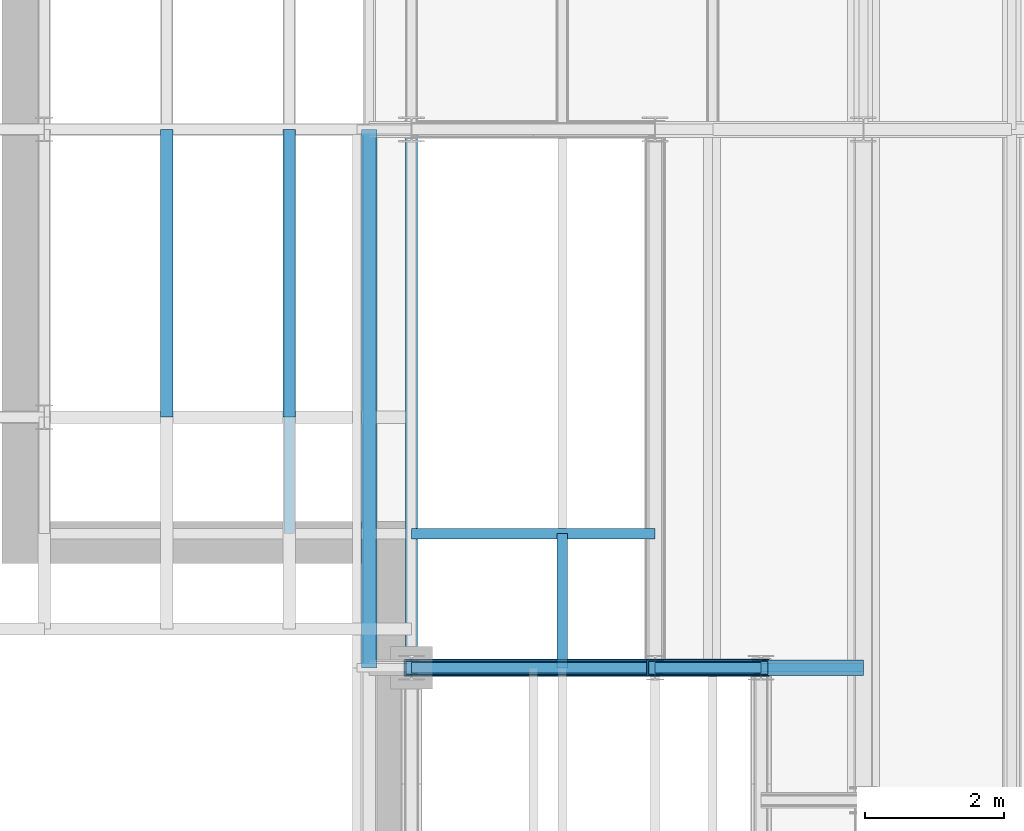
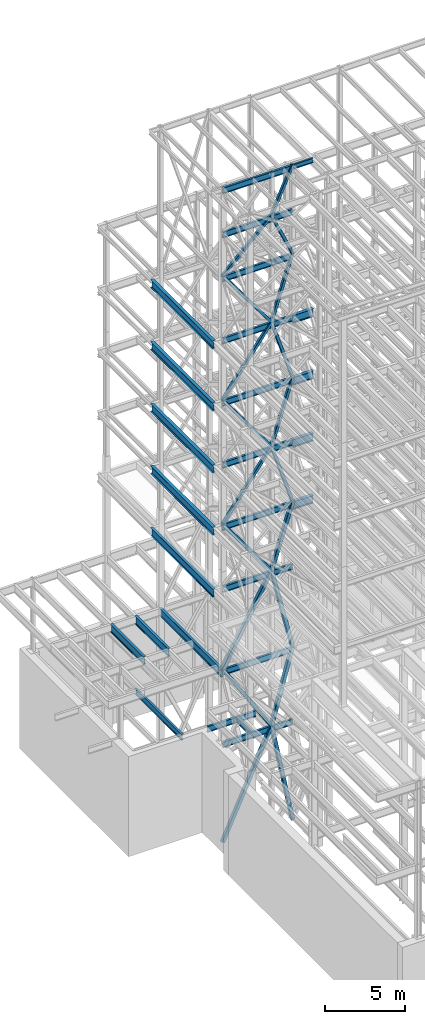
# One storey, part 126 of 150: 55 beams.
"""IFC2X3 building model written with IfcOpenShell, lengths in millimetres."""

from ifc_helpers import new_model, si_unit, frame, origin_with_axes, origin_2d_with_axis, place, context, subcontext, project, spatial, hollow_rectangle, i_section, extrude, material, type_object, element, save


model = new_model("IFC2X3")

# Units and contexts
model_context = context("Model", 3, precision=1e-05, world=origin_with_axes())
body_context = subcontext(model_context, "Body", "Model", "MODEL_VIEW")
ifc_project = project(units=[si_unit("LENGTHUNIT", "METRE", prefix="MILLI"), si_unit("AREAUNIT", "SQUARE_METRE"), si_unit("VOLUMEUNIT", "CUBIC_METRE"), si_unit("MASSUNIT", "GRAM", prefix="KILO"), si_unit("TIMEUNIT", "SECOND"), si_unit("PLANEANGLEUNIT", "RADIAN"), si_unit("SOLIDANGLEUNIT", "STERADIAN"), si_unit("THERMODYNAMICTEMPERATUREUNIT", "DEGREE_CELSIUS"), si_unit("LUMINOUSINTENSITYUNIT", "LUMEN")], contexts=[model_context])

# Site, building, storey
site_placement = place(None, origin_with_axes())
site = spatial("IfcSite", under=ifc_project, at=site_placement, CompositionType="ELEMENT")
building_placement = place(site_placement, origin_with_axes())
building = spatial("IfcBuilding", under=site, at=building_placement, Name="Undefined", CompositionType="ELEMENT")
storey_placement = place(building_placement, origin_with_axes())
storey = spatial("IfcBuildingStorey", under=building, at=storey_placement, Name="Undefined", CompositionType="ELEMENT", Elevation=0.0)

# Beams
ifc_material_1 = material()
beam_type_1 = type_object("IfcBeamType", Name="HSS8X8X3/8", PredefinedType="NOTDEFINED")
beam_1_placement = place(storey_placement, frame((5283.19999999999, 24384.0, 59207.4), z_axis=(-0.691222650508333, 0.0, 0.722641852804164), x_axis=(0.722641852804165, 0.0, 0.691222650508332)))
element("IfcBeam", 1, at=beam_1_placement, inside=storey, type_object=beam_type_1, material=ifc_material_1, Name="BEAM", ObjectType="HSS8X8X3/8", context=body_context, shape_type="SweptSolid", body=[
    extrude(hollow_rectangle(XDim=203.2, YDim=203.2, WallThickness=9.525, InnerFilletRadius=9.5249, OuterFilletRadius=19.0499, at=origin_2d_with_axis()), frame((4850.53495109736, -3.63797880709171e-12, -2.69258779222868e-13), z_axis=(-1.0, 0.0, 0.0), x_axis=(0.0, -1.0, 0.0)), (0.0, 0.0, 1.0), 4850.53495109736),
])
beam_2_placement = place(storey_placement, frame((8788.39962995178, 24383.9996510459, 62560.1997009414), z_axis=(-0.910366535681777, 0.0, 0.413802816218981), x_axis=(0.413802816218983, 0.0, 0.910366535681776)))
element("IfcBeam", 2, at=beam_2_placement, inside=storey, type_object=beam_type_1, material=ifc_material_1, Name="BEAM", ObjectType="HSS8X8X3/8", context=body_context, shape_type="SweptSolid", body=[
    extrude(hollow_rectangle(XDim=203.2, YDim=203.2, WallThickness=9.525, InnerFilletRadius=9.5249, OuterFilletRadius=19.0499, at=origin_2d_with_axis()), frame((3682.91263002186, 0.0, 0.0), z_axis=(-1.0, 0.0, 0.0), x_axis=(0.0, -1.0, 0.0)), (0.0, 0.0, 1.0), 3682.91263002186),
])
beam_3_placement = place(storey_placement, frame((10312.3994840967, 24383.9994993267, 59207.3999481708), z_axis=(0.910366480887262, 0.0, 0.413802936766938), x_axis=(-0.413802936766937, 0.0, 0.910366480887263)))
element("IfcBeam", 3, at=beam_3_placement, inside=storey, type_object=beam_type_1, material=ifc_material_1, Name="BEAM", ObjectType="HSS8X8X3/8", context=body_context, shape_type="SweptSolid", body=[
    extrude(hollow_rectangle(XDim=203.2, YDim=203.2, WallThickness=9.525, InnerFilletRadius=9.5249, OuterFilletRadius=19.0499, at=origin_2d_with_axis()), frame((3682.91245456265, 0.0, 0.0), z_axis=(-1.0, 0.0, 0.0), x_axis=(0.0, -1.0, 0.0)), (0.0, 0.0, 1.0), 3682.91245456265),
])
ifc_material_2 = material(Name="STEEL/A992")
beam_type_2 = type_object("IfcBeamType", Name="W18X35", PredefinedType="NOTDEFINED")
beam_4_placement = place(storey_placement, frame((5283.20000000002, 24384.0, 62334.7746954019), z_axis=(0.0, 0.0, 1.0), x_axis=(1.0, 0.0, 0.0)))
element("IfcBeam", 4, at=beam_4_placement, inside=storey, type_object=beam_type_2, material=ifc_material_2, Name="BEAM", ObjectType="W18X35", context=body_context, shape_type="SweptSolid", body=[
    extrude(i_section(OverallWidth=152.4, OverallDepth=450.85, WebThickness=7.9375, FlangeThickness=10.795, FilletRadius=17.78, at=origin_2d_with_axis()), frame((3505.19949708, 0.0, 0.0), z_axis=(-1.0, 0.0, 0.0), x_axis=(0.0, -1.0, 0.0)), (0.0, 0.0, 1.0), 3505.19949708),
])
beam_5_placement = place(storey_placement, frame((8788.39949708002, 24384.0, 62334.7746954019), z_axis=(0.0, 0.0, 1.0), x_axis=(1.0, 0.0, 0.0)))
element("IfcBeam", 5, at=beam_5_placement, inside=storey, type_object=beam_type_2, material=ifc_material_2, Name="BEAM", ObjectType="W18X35", context=body_context, shape_type="SweptSolid", body=[
    extrude(i_section(OverallWidth=152.4, OverallDepth=450.85, WebThickness=7.9375, FlangeThickness=10.795, FilletRadius=17.78, at=origin_2d_with_axis()), frame((1524.0, 0.0, 0.0), z_axis=(-1.0, 0.0, 0.0), x_axis=(0.0, -1.0, 0.0)), (0.0, 0.0, 1.0), 1524.0),
])
beam_6_placement = place(storey_placement, frame((5283.2, 24384.0, 65687.575), z_axis=(0.0, 0.0, 1.0), x_axis=(1.0, 0.0, 0.0)))
element("IfcBeam", 6, at=beam_6_placement, inside=storey, type_object=beam_type_2, material=ifc_material_2, Name="BEAM", ObjectType="W18X35", context=body_context, shape_type="SweptSolid", body=[
    extrude(i_section(OverallWidth=152.4, OverallDepth=450.85, WebThickness=7.9375, FlangeThickness=10.795, FilletRadius=17.78, at=origin_2d_with_axis()), frame((3505.19949708, 0.0, 0.0), z_axis=(-1.0, 0.0, 0.0), x_axis=(0.0, -1.0, 0.0)), (0.0, 0.0, 1.0), 3505.19949708),
])
beam_7_placement = place(storey_placement, frame((8788.39949708, 24384.0, 65687.575), z_axis=(0.0, 0.0, 1.0), x_axis=(1.0, 0.0, 0.0)))
element("IfcBeam", 7, at=beam_7_placement, inside=storey, type_object=beam_type_2, material=ifc_material_2, Name="BEAM", ObjectType="W18X35", context=body_context, shape_type="SweptSolid", body=[
    extrude(i_section(OverallWidth=152.4, OverallDepth=450.85, WebThickness=7.9375, FlangeThickness=10.795, FilletRadius=17.78, at=origin_2d_with_axis()), frame((1524.0, 0.0, 0.0), z_axis=(-1.0, 0.0, 0.0), x_axis=(0.0, -1.0, 0.0)), (0.0, 0.0, 1.0), 1524.0),
])
beam_8_placement = place(storey_placement, frame((5283.2, 24384.0, 58981.975), z_axis=(0.0, 0.0, 1.0), x_axis=(1.0, 0.0, 0.0)))
element("IfcBeam", 8, at=beam_8_placement, inside=storey, type_object=beam_type_2, material=ifc_material_2, Name="BEAM", ObjectType="W18X35", context=body_context, shape_type="SweptSolid", body=[
    extrude(i_section(OverallWidth=152.4, OverallDepth=450.85, WebThickness=7.9375, FlangeThickness=10.795, FilletRadius=17.78, at=origin_2d_with_axis()), frame((3505.19949708, 0.0, 0.0), z_axis=(-1.0, 0.0, 0.0), x_axis=(0.0, -1.0, 0.0)), (0.0, 0.0, 1.0), 3505.19949708),
])
beam_9_placement = place(storey_placement, frame((8788.39949708, 24384.0, 58981.975), z_axis=(0.0, 0.0, 1.0), x_axis=(1.0, 0.0, 0.0)))
element("IfcBeam", 9, at=beam_9_placement, inside=storey, type_object=beam_type_2, material=ifc_material_2, Name="BEAM", ObjectType="W18X35", context=body_context, shape_type="SweptSolid", body=[
    extrude(i_section(OverallWidth=152.4, OverallDepth=450.85, WebThickness=7.9375, FlangeThickness=10.795, FilletRadius=17.78, at=origin_2d_with_axis()), frame((1524.0, 0.0, 0.0), z_axis=(-1.0, 0.0, 0.0), x_axis=(0.0, -1.0, 0.0)), (0.0, 0.0, 1.0), 1524.0),
])
beam_10_placement = place(storey_placement, frame((5283.2, 24384.0, 54257.575), z_axis=(0.0, 0.0, 1.0), x_axis=(1.0, 0.0, 0.0)))
element("IfcBeam", 10, at=beam_10_placement, inside=storey, type_object=beam_type_2, material=ifc_material_2, Name="BEAM", ObjectType="W18X35", context=body_context, shape_type="SweptSolid", body=[
    extrude(i_section(OverallWidth=152.4, OverallDepth=450.85, WebThickness=7.9375, FlangeThickness=10.795, FilletRadius=17.78, at=origin_2d_with_axis()), frame((3505.19949708, 0.0, 0.0), z_axis=(-1.0, 0.0, 0.0), x_axis=(0.0, -1.0, 0.0)), (0.0, 0.0, 1.0), 3505.19949708),
])
beam_11_placement = place(storey_placement, frame((8788.39949708, 24384.0, 54257.575), z_axis=(0.0, 0.0, 1.0), x_axis=(1.0, 0.0, 0.0)))
element("IfcBeam", 11, at=beam_11_placement, inside=storey, type_object=beam_type_2, material=ifc_material_2, Name="BEAM", ObjectType="W18X35", context=body_context, shape_type="SweptSolid", body=[
    extrude(i_section(OverallWidth=152.4, OverallDepth=450.85, WebThickness=7.9375, FlangeThickness=10.795, FilletRadius=17.78, at=origin_2d_with_axis()), frame((1524.0, 0.0, 0.0), z_axis=(-1.0, 0.0, 0.0), x_axis=(0.0, -1.0, 0.0)), (0.0, 0.0, 1.0), 1524.0),
])
beam_12_placement = place(storey_placement, frame((5283.2, 24384.0, 49533.175), z_axis=(0.0, 0.0, 1.0), x_axis=(1.0, 0.0, 0.0)))
element("IfcBeam", 12, at=beam_12_placement, inside=storey, type_object=beam_type_2, material=ifc_material_2, Name="BEAM", ObjectType="W18X35", context=body_context, shape_type="SweptSolid", body=[
    extrude(i_section(OverallWidth=152.4, OverallDepth=450.85, WebThickness=7.9375, FlangeThickness=10.795, FilletRadius=17.78, at=origin_2d_with_axis()), frame((3505.19949708, 0.0, 0.0), z_axis=(-1.0, 0.0, 0.0), x_axis=(0.0, -1.0, 0.0)), (0.0, 0.0, 1.0), 3505.19949708),
])
beam_13_placement = place(storey_placement, frame((8788.39949708, 24384.0, 49533.175), z_axis=(0.0, 0.0, 1.0), x_axis=(1.0, 0.0, 0.0)))
element("IfcBeam", 13, at=beam_13_placement, inside=storey, type_object=beam_type_2, material=ifc_material_2, Name="BEAM", ObjectType="W18X35", context=body_context, shape_type="SweptSolid", body=[
    extrude(i_section(OverallWidth=152.4, OverallDepth=450.85, WebThickness=7.9375, FlangeThickness=10.795, FilletRadius=17.78, at=origin_2d_with_axis()), frame((1524.0, 0.0, 0.0), z_axis=(-1.0, 0.0, 0.0), x_axis=(0.0, -1.0, 0.0)), (0.0, 0.0, 1.0), 1524.0),
])
beam_14_placement = place(storey_placement, frame((5283.2, 24384.0, 44808.775), z_axis=(0.0, 0.0, 1.0), x_axis=(1.0, 0.0, 0.0)))
element("IfcBeam", 14, at=beam_14_placement, inside=storey, type_object=beam_type_2, material=ifc_material_2, Name="BEAM", ObjectType="W18X35", context=body_context, shape_type="SweptSolid", body=[
    extrude(i_section(OverallWidth=152.4, OverallDepth=450.85, WebThickness=7.9375, FlangeThickness=10.795, FilletRadius=17.78, at=origin_2d_with_axis()), frame((3505.19949708, 0.0, 0.0), z_axis=(-1.0, 0.0, 0.0), x_axis=(0.0, -1.0, 0.0)), (0.0, 0.0, 1.0), 3505.19949708),
])
beam_15_placement = place(storey_placement, frame((8788.39949708, 24384.0, 44808.775), z_axis=(0.0, 0.0, 1.0), x_axis=(1.0, 0.0, 0.0)))
element("IfcBeam", 15, at=beam_15_placement, inside=storey, type_object=beam_type_2, material=ifc_material_2, Name="BEAM", ObjectType="W18X35", context=body_context, shape_type="SweptSolid", body=[
    extrude(i_section(OverallWidth=152.4, OverallDepth=450.85, WebThickness=7.9375, FlangeThickness=10.795, FilletRadius=17.78, at=origin_2d_with_axis()), frame((1524.0, 0.0, 0.0), z_axis=(-1.0, 0.0, 0.0), x_axis=(0.0, -1.0, 0.0)), (0.0, 0.0, 1.0), 1524.0),
])
beam_16_placement = place(storey_placement, frame((5283.2, 24384.0, 40084.375), z_axis=(0.0, 0.0, 1.0), x_axis=(1.0, 0.0, 0.0)))
element("IfcBeam", 16, at=beam_16_placement, inside=storey, type_object=beam_type_2, material=ifc_material_2, Name="BEAM", ObjectType="W18X35", context=body_context, shape_type="SweptSolid", body=[
    extrude(i_section(OverallWidth=152.4, OverallDepth=450.85, WebThickness=7.9375, FlangeThickness=10.795, FilletRadius=17.78, at=origin_2d_with_axis()), frame((3505.19949708, 0.0, 0.0), z_axis=(-1.0, 0.0, 0.0), x_axis=(0.0, -1.0, 0.0)), (0.0, 0.0, 1.0), 3505.19949708),
])
for number, where, z_axis, x_axis, name in (
    (17, (8788.39949708, 24384.0, 40084.375), (0.0, 0.0, 1.0), (1.0, 0.0, 0.0), "BEAM"),
    (18, (8788.39949708, 24384.0, 35359.975), (0.0, 0.0, 1.0), (1.0, 0.0, 0.0), "BEAM"),
):
    element("IfcBeam", number, at=place(storey_placement, frame(where, z_axis=z_axis, x_axis=x_axis)), inside=storey, type_object=beam_type_2, material=ifc_material_2, Name=name, ObjectType="W18X35", context=body_context, shape_type="SweptSolid", body=[
        extrude(i_section(OverallWidth=152.4, OverallDepth=450.85, WebThickness=7.9375, FlangeThickness=10.795, FilletRadius=17.78, at=origin_2d_with_axis()), frame((1524.0, 0.0, 0.0), z_axis=(-1.0, 0.0, 0.0), x_axis=(0.0, -1.0, 0.0)), (0.0, 0.0, 1.0), 1524.0),
    ])
beam_17_placement = place(storey_placement, frame((5283.2, 24384.0, 35359.975), z_axis=(0.0, 0.0, 1.0), x_axis=(1.0, 0.0, 0.0)))
element("IfcBeam", 19, at=beam_17_placement, inside=storey, type_object=beam_type_2, material=ifc_material_2, Name="BEAM", ObjectType="W18X35", context=body_context, shape_type="SweptSolid", body=[
    extrude(i_section(OverallWidth=152.4, OverallDepth=450.85, WebThickness=7.9375, FlangeThickness=10.795, FilletRadius=17.78, at=origin_2d_with_axis()), frame((3505.19949708, 0.0, 0.0), z_axis=(-1.0, 0.0, 0.0), x_axis=(0.0, -1.0, 0.0)), (0.0, 0.0, 1.0), 3505.19949708),
])
beam_18_placement = place(storey_placement, frame((8788.39949708, 24384.0, 29060.775), z_axis=(0.0, 0.0, 1.0), x_axis=(1.0, 0.0, 0.0)))
element("IfcBeam", 20, at=beam_18_placement, inside=storey, type_object=beam_type_2, material=ifc_material_2, Name="BEAM", ObjectType="W18X35", context=body_context, shape_type="SweptSolid", body=[
    extrude(i_section(OverallWidth=152.4, OverallDepth=450.85, WebThickness=7.9375, FlangeThickness=10.795, FilletRadius=17.78, at=origin_2d_with_axis()), frame((1524.0, 0.0, 0.0), z_axis=(-1.0, 0.0, 0.0), x_axis=(0.0, -1.0, 0.0)), (0.0, 0.0, 1.0), 1524.0),
])
beam_19_placement = place(storey_placement, frame((5283.2, 24384.0, 29060.775), z_axis=(0.0, 0.0, 1.0), x_axis=(1.0, 0.0, 0.0)))
element("IfcBeam", 21, at=beam_19_placement, inside=storey, type_object=beam_type_2, material=ifc_material_2, Name="BEAM", ObjectType="W18X35", context=body_context, shape_type="SweptSolid", body=[
    extrude(i_section(OverallWidth=152.4, OverallDepth=450.85, WebThickness=7.9375, FlangeThickness=10.795, FilletRadius=17.78, at=origin_2d_with_axis()), frame((3505.19949708, 0.0, 0.0), z_axis=(-1.0, 0.0, 0.0), x_axis=(0.0, -1.0, 0.0)), (0.0, 0.0, 1.0), 3505.19949708),
])
beam_20_placement = place(storey_placement, frame((3522.13333333333, 26314.4, 23548.975), z_axis=(0.0, 0.0, 1.0), x_axis=(0.0, 1.0, 0.0)))
element("IfcBeam", 22, at=beam_20_placement, inside=storey, type_object=beam_type_2, material=ifc_material_2, Name="BEAM", ObjectType="W18X35", context=body_context, shape_type="SweptSolid", body=[
    extrude(i_section(OverallWidth=152.4, OverallDepth=450.85, WebThickness=7.9375, FlangeThickness=10.795, FilletRadius=17.78, at=origin_2d_with_axis()), frame((5816.59941834001, 0.0, 0.0), z_axis=(-1.0, 0.0, 0.0), x_axis=(0.0, -1.0, 0.0)), (0.0, 0.0, 1.0), 5816.59941834001),
])
beam_21_placement = place(storey_placement, frame((5283.2, 26314.4, 23548.975), z_axis=(0.0, 0.0, 1.0), x_axis=(1.0, 0.0, 0.0)))
element("IfcBeam", 23, at=beam_21_placement, inside=storey, type_object=beam_type_2, material=ifc_material_2, Name="BEAM", ObjectType="W18X35", context=body_context, shape_type="SweptSolid", body=[
    extrude(i_section(OverallWidth=152.4, OverallDepth=450.85, WebThickness=7.9375, FlangeThickness=10.795, FilletRadius=17.78, at=origin_2d_with_axis()), frame((3505.19949708, 0.0, 0.0), z_axis=(-1.0, 0.0, 0.0), x_axis=(0.0, -1.0, 0.0)), (0.0, 0.0, 1.0), 3505.19949708),
])
beam_22_placement = place(storey_placement, frame((7450.66666666666, 24384.0, 23548.975), z_axis=(0.0, 0.0, 1.0), x_axis=(0.0, 1.0, 0.0)))
element("IfcBeam", 24, at=beam_22_placement, inside=storey, type_object=beam_type_2, material=ifc_material_2, Name="BEAM", ObjectType="W18X35", context=body_context, shape_type="SweptSolid", body=[
    extrude(i_section(OverallWidth=152.4, OverallDepth=450.85, WebThickness=7.9375, FlangeThickness=10.795, FilletRadius=17.78, at=origin_2d_with_axis()), frame((1930.4, 0.0, 0.0), z_axis=(-1.0, 0.0, 0.0), x_axis=(0.0, -1.0, 0.0)), (0.0, 0.0, 1.0), 1930.4),
])
beam_23_placement = place(storey_placement, frame((8788.39949708, 24384.0, 23548.975), z_axis=(0.0, 0.0, 1.0), x_axis=(1.0, 0.0, 0.0)))
element("IfcBeam", 25, at=beam_23_placement, inside=storey, type_object=beam_type_2, material=ifc_material_2, Name="BEAM", ObjectType="W18X35", context=body_context, shape_type="SweptSolid", body=[
    extrude(i_section(OverallWidth=152.4, OverallDepth=450.85, WebThickness=7.9375, FlangeThickness=10.795, FilletRadius=17.78, at=origin_2d_with_axis()), frame((1524.0, 0.0, 0.0), z_axis=(-1.0, 0.0, 0.0), x_axis=(0.0, -1.0, 0.0)), (0.0, 0.0, 1.0), 1524.0),
])
beam_24_placement = place(storey_placement, frame((5283.2, 24384.0, 23548.975), z_axis=(0.0, 0.0, 1.0), x_axis=(1.0, 0.0, 0.0)))
element("IfcBeam", 26, at=beam_24_placement, inside=storey, type_object=beam_type_2, material=ifc_material_2, Name="BEAM", ObjectType="W18X35", context=body_context, shape_type="SweptSolid", body=[
    extrude(i_section(OverallWidth=152.4, OverallDepth=450.85, WebThickness=7.9375, FlangeThickness=10.795, FilletRadius=17.78, at=origin_2d_with_axis()), frame((3505.19949708, 0.0, 0.0), z_axis=(-1.0, 0.0, 0.0), x_axis=(0.0, -1.0, 0.0)), (0.0, 0.0, 1.0), 3505.19949708),
])
beam_type_3 = type_object("IfcBeamType", Name="HSS8X8X1/4", PredefinedType="NOTDEFINED")
beam_25_placement = place(storey_placement, frame((8788.39890413715, 24383.9996510459, 54482.9985485445), z_axis=(0.803098244341145, 0.0, 0.595846632898241), x_axis=(-0.595846632898242, 0.0, 0.803098244341144)))
element("IfcBeam", 27, at=beam_25_placement, inside=storey, type_object=beam_type_3, material=ifc_material_1, Name="BEAM", ObjectType="HSS8X8X1/4", context=body_context, shape_type="SweptSolid", body=[
    extrude(hollow_rectangle(XDim=203.2, YDim=203.2, WallThickness=6.35, InnerFilletRadius=6.3499, OuterFilletRadius=12.6999, at=origin_2d_with_axis()), frame((5882.71947589545, 0.0, 3.26556530477498e-13), z_axis=(-1.0, 0.0, 0.0), x_axis=(0.0, -1.0, 0.0)), (0.0, 0.0, 1.0), 5882.71947589545),
])
beam_26_placement = place(storey_placement, frame((5283.19999999999, 24384.0, 49758.6), z_axis=(-0.803098029777427, 0.0, 0.595846922092927), x_axis=(0.595846922092929, 0.0, 0.803098029777426)))
element("IfcBeam", 28, at=beam_26_placement, inside=storey, type_object=beam_type_3, material=ifc_material_1, Name="BEAM", ObjectType="HSS8X8X1/4", context=body_context, shape_type="SweptSolid", body=[
    extrude(hollow_rectangle(XDim=203.2, YDim=203.2, WallThickness=6.35, InnerFilletRadius=6.3499, OuterFilletRadius=12.6999, at=origin_2d_with_axis()), frame((5882.71736269412, -3.63797880709171e-12, -6.53112826342519e-13), z_axis=(-1.0, 0.0, 0.0), x_axis=(0.0, -1.0, 0.0)), (0.0, 0.0, 1.0), 5882.71736269412),
])
beam_27_placement = place(storey_placement, frame((8788.39907224921, 24383.9996510459, 45034.1981868516), z_axis=(0.803098244341145, 0.0, 0.595846632898241), x_axis=(-0.595846632898242, 0.0, 0.803098244341144)))
element("IfcBeam", 29, at=beam_27_placement, inside=storey, type_object=beam_type_3, material=ifc_material_1, Name="BEAM", ObjectType="HSS8X8X1/4", context=body_context, shape_type="SweptSolid", body=[
    extrude(hollow_rectangle(XDim=203.2, YDim=203.2, WallThickness=6.35, InnerFilletRadius=6.3499, OuterFilletRadius=12.6999, at=origin_2d_with_axis()), frame((5882.71986653939, -3.63797880709171e-12, 0.0), z_axis=(-1.0, 0.0, 0.0), x_axis=(0.0, -1.0, 0.0)), (0.0, 0.0, 1.0), 5882.71986653939),
])
beam_28_placement = place(storey_placement, frame((5283.19999999999, 24384.0, 40309.8), z_axis=(-0.803098029777427, 0.0, 0.595846922092927), x_axis=(0.595846922092929, 0.0, 0.803098029777426)))
element("IfcBeam", 30, at=beam_28_placement, inside=storey, type_object=beam_type_3, material=ifc_material_1, Name="BEAM", ObjectType="HSS8X8X1/4", context=body_context, shape_type="SweptSolid", body=[
    extrude(hollow_rectangle(XDim=203.2, YDim=203.2, WallThickness=6.35, InnerFilletRadius=6.3499, OuterFilletRadius=12.6999, at=origin_2d_with_axis()), frame((5882.7176448609, -3.63797880709171e-12, -6.53112857669324e-13), z_axis=(-1.0, 0.0, 0.0), x_axis=(0.0, -1.0, 0.0)), (0.0, 0.0, 1.0), 5882.7176448609),
])
beam_29_placement = place(storey_placement, frame((8788.39897512157, 24383.9996510459, 54482.9987674781), z_axis=(-0.951708610220493, 0.0, 0.307002803296936), x_axis=(0.307002803296934, 0.0, 0.951708610220494)))
element("IfcBeam", 31, at=beam_29_placement, inside=storey, type_object=beam_type_3, material=ifc_material_1, Name="BEAM", ObjectType="HSS8X8X1/4", context=body_context, shape_type="SweptSolid", body=[
    extrude(hollow_rectangle(XDim=203.2, YDim=203.2, WallThickness=6.35, InnerFilletRadius=6.3499, OuterFilletRadius=12.6999, at=origin_2d_with_axis()), frame((4964.12576359461, -3.63797880709171e-12, 0.0), z_axis=(-1.0, 0.0, 0.0), x_axis=(0.0, -1.0, 0.0)), (0.0, 0.0, 1.0), 4964.12576359461),
])
beam_30_placement = place(storey_placement, frame((10312.3994243435, 24383.9994993267, 49758.5998073386), z_axis=(0.951708571577691, 0.0, 0.307002923089589), x_axis=(-0.307002923089589, 0.0, 0.95170857157769)))
element("IfcBeam", 32, at=beam_30_placement, inside=storey, type_object=beam_type_3, material=ifc_material_1, Name="BEAM", ObjectType="HSS8X8X1/4", context=body_context, shape_type="SweptSolid", body=[
    extrude(hollow_rectangle(XDim=203.2, YDim=203.2, WallThickness=6.35, InnerFilletRadius=6.3499, OuterFilletRadius=12.6999, at=origin_2d_with_axis()), frame((4964.12395196718, -3.63797880709171e-12, 0.0), z_axis=(-1.0, 0.0, 0.0), x_axis=(0.0, -1.0, 0.0)), (0.0, 0.0, 1.0), 4964.12395196718),
])
beam_31_placement = place(storey_placement, frame((8788.39945557969, 24383.9996510459, 45034.1987623571), z_axis=(-0.951708610220493, 0.0, 0.307002803296936), x_axis=(0.307002803296934, 0.0, 0.951708610220494)))
element("IfcBeam", 33, at=beam_31_placement, inside=storey, type_object=beam_type_3, material=ifc_material_1, Name="BEAM", ObjectType="HSS8X8X1/4", context=body_context, shape_type="SweptSolid", body=[
    extrude(hollow_rectangle(XDim=203.2, YDim=203.2, WallThickness=6.35, InnerFilletRadius=6.3499, OuterFilletRadius=12.6999, at=origin_2d_with_axis()), frame((4964.12562096637, 3.63797880709171e-12, 1.18505902984935e-12), z_axis=(-1.0, 0.0, 0.0), x_axis=(0.0, -1.0, 0.0)), (0.0, 0.0, 1.0), 4964.12562096637),
])
beam_32_placement = place(storey_placement, frame((10312.3994104483, 24383.9994993267, 40309.7997957603), z_axis=(0.951708571577691, 0.0, 0.307002923089589), x_axis=(-0.307002923089589, 0.0, 0.95170857157769)))
element("IfcBeam", 34, at=beam_32_placement, inside=storey, type_object=beam_type_3, material=ifc_material_1, Name="BEAM", ObjectType="HSS8X8X1/4", context=body_context, shape_type="SweptSolid", body=[
    extrude(hollow_rectangle(XDim=203.2, YDim=203.2, WallThickness=6.35, InnerFilletRadius=6.3499, OuterFilletRadius=12.6999, at=origin_2d_with_axis()), frame((4964.12395196718, -3.63797880709171e-12, 0.0), z_axis=(-1.0, 0.0, 0.0), x_axis=(0.0, -1.0, 0.0)), (0.0, 0.0, 1.0), 4964.1239587205),
])
beam_type_4 = type_object("IfcBeamType", Name="HSS10X10X1/2", PredefinedType="NOTDEFINED")
beam_33_placement = place(storey_placement, frame((8788.39819527373, 24383.999651046, 35585.4), z_axis=(0.803098244341145, 0.0, 0.595846632898241), x_axis=(-0.595846632898242, 0.0, 0.803098244341144)))
element("IfcBeam", 35, at=beam_33_placement, inside=storey, type_object=beam_type_4, material=ifc_material_1, Name="BEAM", ObjectType="HSS10X10X1/2", context=body_context, shape_type="SweptSolid", body=[
    extrude(hollow_rectangle(XDim=254.0, YDim=254.0, WallThickness=12.7, InnerFilletRadius=12.6999, OuterFilletRadius=25.3999, at=origin_2d_with_axis()), frame((5882.7178878602, 3.63797880709171e-12, 6.53112884647667e-13), z_axis=(-1.0, 0.0, 0.0), x_axis=(0.0, -1.0, 0.0)), (0.0, 0.0, 1.0), 5882.7178878602),
])
beam_34_placement = place(storey_placement, frame((5283.20033251794, 24384.0, 29286.2), z_axis=(-0.873824779009973, 0.0, 0.486240943965204), x_axis=(0.486240943965203, 0.0, 0.873824779009973)))
element("IfcBeam", 36, at=beam_34_placement, inside=storey, type_object=beam_type_4, material=ifc_material_1, Name="BEAM", ObjectType="HSS10X10X1/2", context=body_context, shape_type="SweptSolid", body=[
    extrude(hollow_rectangle(XDim=254.0, YDim=254.0, WallThickness=12.7, InnerFilletRadius=12.6999, OuterFilletRadius=25.3999, at=origin_2d_with_axis()), frame((7208.76776551082, 7.27595761418343e-12, -4.00166997622288e-13), z_axis=(-1.0, 0.0, 0.0), x_axis=(0.0, -1.0, 0.0)), (0.0, 0.0, 1.0), 7208.76776551082),
])
beam_35_placement = place(storey_placement, frame((8788.39819527374, 24383.999651046, 23774.4), z_axis=(0.843821721320064, 0.0, 0.536623613558372), x_axis=(-0.536623613558373, 0.0, 0.843821721320063)))
element("IfcBeam", 37, at=beam_35_placement, inside=storey, type_object=beam_type_4, material=ifc_material_1, Name="BEAM", ObjectType="HSS10X10X1/2", context=body_context, shape_type="SweptSolid", body=[
    extrude(hollow_rectangle(XDim=254.0, YDim=254.0, WallThickness=12.7, InnerFilletRadius=12.6999, OuterFilletRadius=25.3999, at=origin_2d_with_axis()), frame((6531.94850692104, 3.63797880709171e-12, -7.25191962804965e-13), z_axis=(-1.0, 0.0, 0.0), x_axis=(0.0, -1.0, 0.0)), (0.0, 0.0, 1.0), 6531.94850692104),
])
beam_36_placement = place(storey_placement, frame((8788.39819527373, 24383.999651046, 35585.4), z_axis=(-0.951708610220493, 0.0, 0.307002803296936), x_axis=(0.307002803296934, 0.0, 0.951708610220494)))
element("IfcBeam", 38, at=beam_36_placement, inside=storey, type_object=beam_type_4, material=ifc_material_1, Name="BEAM", ObjectType="HSS10X10X1/2", context=body_context, shape_type="SweptSolid", body=[
    extrude(hollow_rectangle(XDim=254.0, YDim=254.0, WallThickness=12.7, InnerFilletRadius=12.6999, OuterFilletRadius=25.3999, at=origin_2d_with_axis()), frame((4964.12483000856, -3.63797880709171e-12, 0.0), z_axis=(-1.0, 0.0, 0.0), x_axis=(0.0, -1.0, 0.0)), (0.0, 0.0, 1.0), 4964.12483000856),
])
beam_37_placement = place(storey_placement, frame((10312.3990503354, 24383.9994993267, 29286.1997756512), z_axis=(0.971958750820007, 0.0, 0.235151412295167), x_axis=(-0.235151412295168, 0.0, 0.971958750820007)))
element("IfcBeam", 39, at=beam_37_placement, inside=storey, type_object=beam_type_4, material=ifc_material_1, Name="BEAM", ObjectType="HSS10X10X1/2", context=body_context, shape_type="SweptSolid", body=[
    extrude(hollow_rectangle(XDim=254.0, YDim=254.0, WallThickness=12.7, InnerFilletRadius=12.6999, OuterFilletRadius=25.3999, at=origin_2d_with_axis()), frame((6480.93373463002, -3.63797880709171e-12, -1.79882046331404e-13), z_axis=(-1.0, 0.0, 0.0), x_axis=(0.0, -1.0, 0.0)), (0.0, 0.0, 1.0), 6480.93373463002),
])
beam_38_placement = place(storey_placement, frame((8788.39819527374, 24383.999651046, 23774.4), z_axis=(-0.963835356515138, 0.0, 0.266498415626315), x_axis=(0.266498415626315, 0.0, 0.963835356515138)))
element("IfcBeam", 40, at=beam_38_placement, inside=storey, type_object=beam_type_4, material=ifc_material_1, Name="BEAM", ObjectType="HSS10X10X1/2", context=body_context, shape_type="SweptSolid", body=[
    extrude(hollow_rectangle(XDim=254.0, YDim=254.0, WallThickness=12.7, InnerFilletRadius=12.6999, OuterFilletRadius=25.3999, at=origin_2d_with_axis()), frame((5718.61165038399, 0.0, 0.0), z_axis=(-1.0, 0.0, 0.0), x_axis=(0.0, -1.0, 0.0)), (0.0, 0.0, 1.0), 5718.61165038399),
])
beam_39_placement = place(storey_placement, frame((10312.399829598, 24383.9994993266, 16154.4), z_axis=(0.980580641075519, 0.0, 0.196116308215111), x_axis=(-0.196116308215111, 0.0, 0.980580641075519)))
element("IfcBeam", 41, at=beam_39_placement, inside=storey, type_object=beam_type_4, material=ifc_material_1, Name="BEAM", ObjectType="HSS10X10X1/2", context=body_context, shape_type="SweptSolid", body=[
    extrude(hollow_rectangle(XDim=254.0, YDim=254.0, WallThickness=12.7, InnerFilletRadius=12.6999, OuterFilletRadius=25.3999, at=origin_2d_with_axis()), frame((7770.90605923294, 0.0, -2.15685970728989e-13), z_axis=(-1.0, 0.0, 0.0), x_axis=(0.0, -1.0, 0.0)), (0.0, 0.0, 1.0), 7770.90605923294),
])
beam_40_placement = place(storey_placement, frame((5283.19999999999, 24384.0, 16154.4), z_axis=(-0.908490540001108, 0.0, 0.417905418400499), x_axis=(0.417905418400499, 0.0, 0.908490540001107)))
element("IfcBeam", 42, at=beam_40_placement, inside=storey, type_object=beam_type_4, material=ifc_material_1, Name="BEAM", ObjectType="HSS10X10X1/2", context=body_context, shape_type="SweptSolid", body=[
    extrude(hollow_rectangle(XDim=254.0, YDim=254.0, WallThickness=12.7, InnerFilletRadius=12.6999, OuterFilletRadius=25.3999, at=origin_2d_with_axis()), frame((8387.53923318097, -3.63797880709171e-12, 0.0), z_axis=(-1.0, 0.0, 0.0), x_axis=(0.0, -1.0, 0.0)), (0.0, 0.0, 1.0), 8387.53923318097),
])
beam_type_5 = type_object("IfcBeamType", Name="W24X68", PredefinedType="NOTDEFINED")
beam_41_placement = place(storey_placement, frame((10312.39949708, 24384.0, 54181.375), z_axis=(0.0, 0.0, 1.0), x_axis=(1.0, 0.0, 0.0)))
element("IfcBeam", 43, at=beam_41_placement, inside=storey, type_object=beam_type_5, material=ifc_material_2, Name="BEAM", ObjectType="W24X68", context=body_context, shape_type="SweptSolid", body=[
    extrude(i_section(OverallWidth=227.838, OverallDepth=603.25, WebThickness=11.1125, FlangeThickness=14.859, FilletRadius=23.2409, at=origin_2d_with_axis()), frame((1473.20050292, 0.0, 0.0), z_axis=(-1.0, 0.0, 0.0), x_axis=(0.0, -1.0, 0.0)), (0.0, 0.0, 1.0), 1473.20050292),
])
beam_42_placement = place(storey_placement, frame((4673.6, 24384.0, 54181.375), z_axis=(0.0, 0.0, 1.0), x_axis=(0.0, 1.0, 0.0)))
element("IfcBeam", 44, at=beam_42_placement, inside=storey, type_object=beam_type_5, material=ifc_material_2, Name="BEAM", ObjectType="W24X68", context=body_context, shape_type="SweptSolid", body=[
    extrude(i_section(OverallWidth=227.838, OverallDepth=603.25, WebThickness=11.1125, FlangeThickness=14.859, FilletRadius=23.2409, at=origin_2d_with_axis()), frame((7747.0, 0.0, 0.0), z_axis=(-1.0, 0.0, 0.0), x_axis=(0.0, -1.0, 0.0)), (0.0, 0.0, 1.0), 7747.0),
])
beam_43_placement = place(storey_placement, frame((10312.39949708, 24384.0, 49456.975), z_axis=(0.0, 0.0, 1.0), x_axis=(1.0, 0.0, 0.0)))
element("IfcBeam", 45, at=beam_43_placement, inside=storey, type_object=beam_type_5, material=ifc_material_2, Name="BEAM", ObjectType="W24X68", context=body_context, shape_type="SweptSolid", body=[
    extrude(i_section(OverallWidth=227.838, OverallDepth=603.25, WebThickness=11.1125, FlangeThickness=14.859, FilletRadius=23.2409, at=origin_2d_with_axis()), frame((1473.20050292, 0.0, 0.0), z_axis=(-1.0, 0.0, 0.0), x_axis=(0.0, -1.0, 0.0)), (0.0, 0.0, 1.0), 1473.20050292),
])
beam_44_placement = place(storey_placement, frame((4673.6, 24384.0, 49456.975), z_axis=(0.0, 0.0, 1.0), x_axis=(0.0, 1.0, 0.0)))
element("IfcBeam", 46, at=beam_44_placement, inside=storey, type_object=beam_type_5, material=ifc_material_2, Name="BEAM", ObjectType="W24X68", context=body_context, shape_type="SweptSolid", body=[
    extrude(i_section(OverallWidth=227.838, OverallDepth=603.25, WebThickness=11.1125, FlangeThickness=14.859, FilletRadius=23.2409, at=origin_2d_with_axis()), frame((7747.0, 0.0, 0.0), z_axis=(-1.0, 0.0, 0.0), x_axis=(0.0, -1.0, 0.0)), (0.0, 0.0, 1.0), 7747.0),
])
beam_45_placement = place(storey_placement, frame((10312.39949708, 24384.0, 44732.575), z_axis=(0.0, 0.0, 1.0), x_axis=(1.0, 0.0, 0.0)))
element("IfcBeam", 47, at=beam_45_placement, inside=storey, type_object=beam_type_5, material=ifc_material_2, Name="BEAM", ObjectType="W24X68", context=body_context, shape_type="SweptSolid", body=[
    extrude(i_section(OverallWidth=227.838, OverallDepth=603.25, WebThickness=11.1125, FlangeThickness=14.859, FilletRadius=23.2409, at=origin_2d_with_axis()), frame((1473.20050292, 0.0, 0.0), z_axis=(-1.0, 0.0, 0.0), x_axis=(0.0, -1.0, 0.0)), (0.0, 0.0, 1.0), 1473.20050292),
])
beam_46_placement = place(storey_placement, frame((4673.6, 24384.0, 44732.575), z_axis=(0.0, 0.0, 1.0), x_axis=(0.0, 1.0, 0.0)))
element("IfcBeam", 48, at=beam_46_placement, inside=storey, type_object=beam_type_5, material=ifc_material_2, Name="BEAM", ObjectType="W24X68", context=body_context, shape_type="SweptSolid", body=[
    extrude(i_section(OverallWidth=227.838, OverallDepth=603.25, WebThickness=11.1125, FlangeThickness=14.859, FilletRadius=23.2409, at=origin_2d_with_axis()), frame((7747.0, 0.0, 0.0), z_axis=(-1.0, 0.0, 0.0), x_axis=(0.0, -1.0, 0.0)), (0.0, 0.0, 1.0), 7747.0),
])
beam_47_placement = place(storey_placement, frame((10312.39949708, 24384.0, 40008.175), z_axis=(0.0, 0.0, 1.0), x_axis=(1.0, 0.0, 0.0)))
element("IfcBeam", 49, at=beam_47_placement, inside=storey, type_object=beam_type_5, material=ifc_material_2, Name="BEAM", ObjectType="W24X68", context=body_context, shape_type="SweptSolid", body=[
    extrude(i_section(OverallWidth=227.838, OverallDepth=603.25, WebThickness=11.1125, FlangeThickness=14.859, FilletRadius=23.2409, at=origin_2d_with_axis()), frame((1473.20050292, 0.0, 0.0), z_axis=(-1.0, 0.0, 0.0), x_axis=(0.0, -1.0, 0.0)), (0.0, 0.0, 1.0), 1473.20050292),
])
beam_48_placement = place(storey_placement, frame((4673.6, 24384.0, 40008.175), z_axis=(0.0, 0.0, 1.0), x_axis=(0.0, 1.0, 0.0)))
element("IfcBeam", 50, at=beam_48_placement, inside=storey, type_object=beam_type_5, material=ifc_material_2, Name="BEAM", ObjectType="W24X68", context=body_context, shape_type="SweptSolid", body=[
    extrude(i_section(OverallWidth=227.838, OverallDepth=603.25, WebThickness=11.1125, FlangeThickness=14.859, FilletRadius=23.2409, at=origin_2d_with_axis()), frame((7747.0, 0.0, 0.0), z_axis=(-1.0, 0.0, 0.0), x_axis=(0.0, -1.0, 0.0)), (0.0, 0.0, 1.0), 7747.0),
])
beam_type_6 = type_object("IfcBeamType", Name="W14X22", PredefinedType="NOTDEFINED")
beam_49_placement = place(storey_placement, frame((10312.39949708, 24384.0, 65738.375), z_axis=(0.0, 0.0, 1.0), x_axis=(1.0, 0.0, 0.0)))
element("IfcBeam", 51, at=beam_49_placement, inside=storey, type_object=beam_type_6, material=ifc_material_2, Name="BEAM", ObjectType="W14X22", context=body_context, shape_type="SweptSolid", body=[
    extrude(i_section(OverallWidth=127.0, OverallDepth=349.25, WebThickness=6.3499, FlangeThickness=8.509, FilletRadius=18.4785, at=origin_2d_with_axis()), frame((1473.20050292, 0.0, 0.0), z_axis=(-1.0, 0.0, 0.0), x_axis=(0.0, -1.0, 0.0)), (0.0, 0.0, 1.0), 1473.20050292),
])
beam_type_7 = type_object("IfcBeamType", Name="W24X55", PredefinedType="NOTDEFINED")
beam_50_placement = place(storey_placement, frame((5283.2, 24384.0, 28986.1625), z_axis=(0.0, 0.0, 1.0), x_axis=(0.0, 1.0, 0.0)))
element("IfcBeam", 52, at=beam_50_placement, inside=storey, type_object=beam_type_7, material=ifc_material_2, Name="BEAM", ObjectType="W24X55", context=body_context, shape_type="SweptSolid", body=[
    extrude(i_section(OverallWidth=178.054, OverallDepth=600.075, WebThickness=9.5249, FlangeThickness=12.827, FilletRadius=23.6854, at=origin_2d_with_axis()), frame((7747.0, 0.0, 0.0), z_axis=(-1.0, 0.0, 0.0), x_axis=(0.0, -1.0, 0.0)), (0.0, 0.0, 1.0), 7747.0),
])
for number, where, z_axis, x_axis, name in (
    (53, (3522.13333333333, 27990.8, 28986.1625), (0.0, 0.0, 1.0), (0.0, 1.0, 0.0), "BEAM"),
    (54, (1761.06666666667, 27990.8, 28986.1625), (0.0, 0.0, 1.0), (0.0, 1.0, 0.0), "BEAM"),
):
    element("IfcBeam", number, at=place(storey_placement, frame(where, z_axis=z_axis, x_axis=x_axis)), inside=storey, type_object=beam_type_7, material=ifc_material_2, Name=name, ObjectType="W24X55", context=body_context, shape_type="SweptSolid", body=[
        extrude(i_section(OverallWidth=178.054, OverallDepth=600.075, WebThickness=9.5249, FlangeThickness=12.827, FilletRadius=23.6854, at=origin_2d_with_axis()), frame((4140.2, 0.0, 0.0), z_axis=(-1.0, 0.0, 0.0), x_axis=(0.0, -1.0, 0.0)), (0.0, 0.0, 1.0), 4140.2),
    ])
beam_type_8 = type_object("IfcBeamType", Name="W24X62", PredefinedType="NOTDEFINED")
beam_51_placement = place(storey_placement, frame((4673.6, 24384.0, 35283.775), z_axis=(0.0, 0.0, 1.0), x_axis=(0.0, 1.0, 0.0)))
element("IfcBeam", 55, at=beam_51_placement, inside=storey, type_object=beam_type_8, material=ifc_material_2, Name="BEAM", ObjectType="W24X62", context=body_context, shape_type="SweptSolid", body=[
    extrude(i_section(OverallWidth=177.8, OverallDepth=603.25, WebThickness=11.1125, FlangeThickness=14.986, FilletRadius=23.114, at=origin_2d_with_axis()), frame((7747.0, 0.0, 0.0), z_axis=(-1.0, 0.0, 0.0), x_axis=(0.0, -1.0, 0.0)), (0.0, 0.0, 1.0), 7747.0),
])

save(model, "model.ifc")
